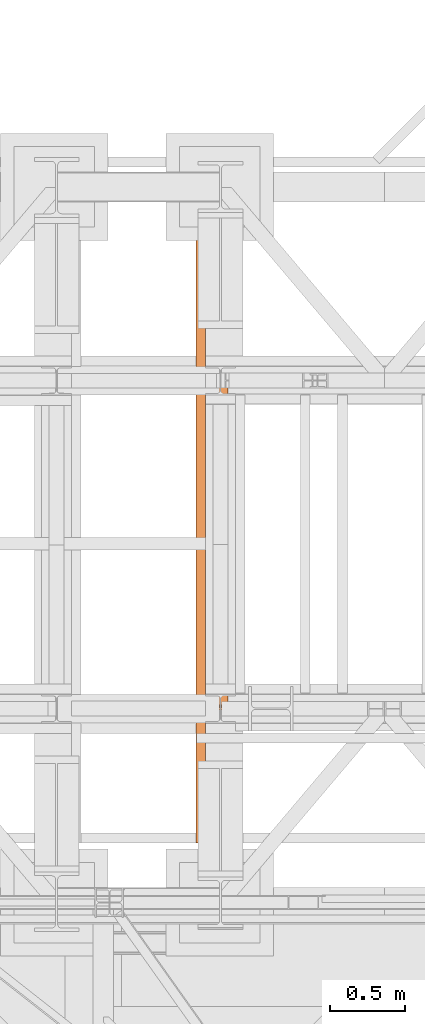
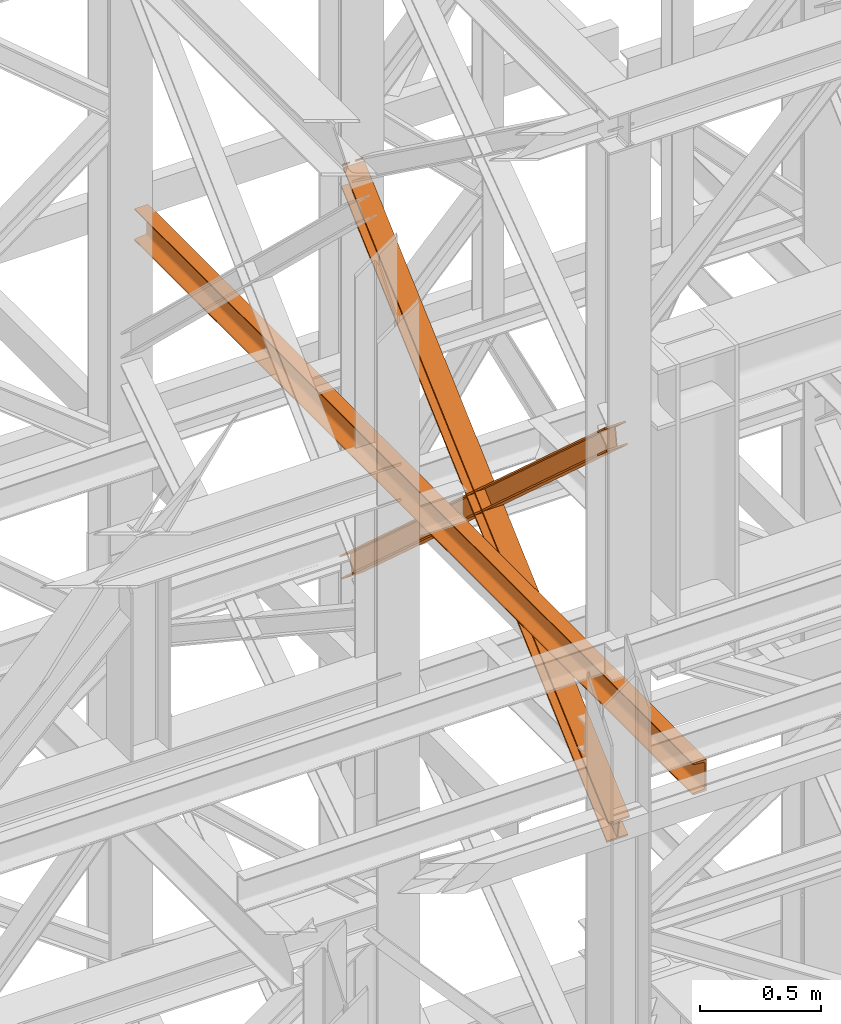
# One storey, part 126 of 208: 3 proxies.
"""IFC2X3 building model written with IfcOpenShell, lengths in millimetres."""

from ifc_helpers import new_model, entity, si_unit, converted_unit, frame, origin, origin_with_axes, place, context, subcontext, project, spatial, faceted_brep, element, save


model = new_model("IFC2X3")

# Units and contexts
model_context = context("Model", 3, precision=1e-05, world=origin())
plan_context = context("Plan", 3, precision=1e-05, world=origin())
body_context = subcontext(model_context, "Body", "Model", "MODEL_VIEW")
ifc_project = project(units=[si_unit("LENGTHUNIT", "METRE", prefix="MILLI"), converted_unit("PLANEANGLEUNIT", "DEGREE", entity("IfcPlaneAngleMeasure", 0.0174532925199433), si_unit("PLANEANGLEUNIT", "RADIAN"), dimensions=[0, 0, 0, 0, 0, 0, 0]), si_unit("AREAUNIT", "SQUARE_METRE"), si_unit("VOLUMEUNIT", "CUBIC_METRE")], contexts=[model_context, plan_context])

# Building, storey
building_placement = place(None, origin())
building = spatial("IfcBuilding", under=ifc_project, at=building_placement, CompositionType="COMPLEX")
storey_placement = place(building_placement, origin_with_axes())
storey = spatial("IfcBuildingStorey", under=building, at=storey_placement, Name="Geschoss", CompositionType="ELEMENT")

# Proxies
proxy_1_placement = place(storey_placement, frame((3242.676947659522, -15970.94025142175, 8709.664099392032), z_axis=(0.0, 0.0, 1.0), x_axis=(1.0, 0.0, 0.0)))
element("IfcBuildingElementProxy", 1, at=proxy_1_placement, inside=storey, context=body_context, shape_type="Brep", body=[
    faceted_brep([(100.0233874223195, 2202.524047252906, 1969.026231437971), (100.2041359483605, 16.74193427489081, 0.02100513656296243), (100.2031119106664, 15.34760641933463, 9.331797992270367), (100.0223627570795, 2201.129719715085, 1978.337022171885), (0.02338802788472094, 2202.524047252906, 1969.015226301408), (0.204136553925764, 16.74193427489081, 0.01000000000021828), (100.2041359483605, 16.74193427489081, 0.02100513656296243), (100.0233874223195, 2202.524047252906, 1969.026231437971), (0.02236336264650163, 2201.129719715083, 1978.32601703533), (0.203112516231613, 15.34760641933463, 9.320792855700347), (0.204136553925764, 16.74193427489081, 0.01000000000021828), (0.02338802788472094, 2202.524047252906, 1969.015226301408), (47.52236307500243, 2201.129719715083, 1978.331244475192), (47.70311222858754, 15.34760641933463, 9.326020295562557), (0.203112516231613, 15.34760641933463, 9.320792855700347), (0.02236336264650163, 2201.129719715083, 1978.32601703533), (47.51211642258568, 2187.186444336861, 2071.439151814395), (47.6928718651684, 1.404327856926102, 102.4339488982641), (47.70311222858754, 15.34760641933463, 9.326020295562557), (47.52236307500243, 2201.129719715083, 1978.331244475192), (0.0110594602265337, 2197.850904391578, 2081.040801967907), (0.01123343514518638, 2196.096022801514, 2079.459950003524), (29.30670605184969, 2196.096022801514, 2079.463174010305), (38.62248918838486, 2197.75725418804, 2080.960688188874), (38.72759933923771, 2197.85090439158, 2081.04506277602), (47.51211642258568, 2187.186444336861, 2071.439151814395), (0.0121167102297477, 2187.186444336861, 2071.433924374533), (0.1928721528142887, 1.404327856924283, 102.4287214583947), (47.6928718651684, 1.404327856926102, 102.4339488982641), (0.01000000000021828, 2196.807553171771, 2090.667763094707), (0.01020876990332909, 2194.701695263691, 2088.770740737438), (0.01123343514518638, 2196.096022801514, 2079.459950003524), (0.0110594602265337, 2197.850904391578, 2081.040801967907), (0.0121167102297477, 2187.186444336861, 2071.433924374533), (0.01109204498970939, 2185.792116799039, 2080.744715108447), (0.1918481178249749, 0.00999999999839929, 111.7395143232407), (0.1928721528142887, 1.404327856924283, 102.4287214583947), (100.0099993944386, 2196.80755317177, 2090.67876823127), (100.0102081643418, 2194.701695263691, 2088.781745874001), (71.80672165016404, 2194.701695263691, 2088.778642041782), (62.49088072881023, 2196.362926650216, 2090.274105784663), (61.99182992716487, 2196.80755317177, 2090.674584279774), (0.01109204498970939, 2185.792116799039, 2080.744715108447), (100.0110914394281, 2185.792116799039, 2080.755720245017), (100.1918475122634, 0.00999999999839929, 111.7505194598034), (0.1918481178249749, 0.00999999999839929, 111.7395143232407), (0.01020876990332909, 2194.701695263691, 2088.770740737438), (0.01000000000021828, 2196.807553171771, 2090.667763094707), (39.12153594998199, 2196.807553171771, 2090.672067372672), (38.62250061437408, 2196.362926650216, 2090.271479036817), (29.3067174778389, 2194.701695263691, 2088.773964858256), (100.0110588546631, 2197.85090439158, 2081.051807104463), (100.01123282958, 2196.096022801514, 2079.470955140079), (100.0102081643418, 2194.701695263691, 2088.781745874001), (100.0099993944386, 2196.80755317177, 2090.67876823127), (100.0110914394281, 2185.792116799039, 2080.755720245017), (100.0121161046682, 2187.186444336861, 2071.444929511088), (100.1928715472454, 1.404327856926102, 102.4397265949574), (100.1918475122634, 0.00999999999839929, 111.7505194598034), (52.5121163923086, 2187.186444336861, 2071.439702071226), (52.69287183489314, 1.404327856924283, 102.4344991550879), (100.1928715472454, 1.404327856926102, 102.4397265949574), (100.0121161046682, 2187.186444336861, 2071.444929511088), (71.80671022417482, 2196.096022801516, 2079.467851193831), (100.01123282958, 2196.096022801514, 2079.470955140079), (100.0110588546631, 2197.85090439158, 2081.051807104463), (62.38575589440734, 2197.85090439158, 2081.047666388475), (62.49086930282101, 2197.75725418804, 2080.963314936713), (52.52236304472172, 2201.129719715083, 1978.331794732023), (52.70311219830865, 15.34760641933463, 9.326570552393605), (52.69287183489314, 1.404327856924283, 102.4344991550879), (52.5121163923086, 2187.186444336861, 2071.439702071226), (100.0223627570795, 2201.129719715085, 1978.337022171885), (100.2031119106664, 15.34760641933463, 9.331797992270367), (52.70311219830865, 15.34760641933463, 9.326570552393605), (52.52236304472172, 2201.129719715083, 1978.331794732023), (62.38575589440734, 2197.85090439158, 2081.047666388475), (100.0110588546631, 2197.85090439158, 2081.051807104463), (100.0099993944386, 2196.80755317177, 2090.67876823127), (61.99182992716487, 2196.80755317177, 2090.674584279774), (39.12153594998199, 2196.807553171771, 2090.672067372672), (0.01000000000021828, 2196.807553171771, 2090.667763094707), (0.0110594602265337, 2197.850904391578, 2081.040801967907), (38.72759933923771, 2197.85090439158, 2081.04506277602), (62.49086930282101, 2197.75725418804, 2080.963314936713), (62.38575589440734, 2197.85090439158, 2081.047666388475), (61.99182992716487, 2196.80755317177, 2090.674584279774), (62.49088072881023, 2196.362926650216, 2090.274105784663), (62.49088072881023, 2196.362926650216, 2090.274105784663), (71.80672165016404, 2194.701695263691, 2088.778642041782), (71.80671022417482, 2196.096022801516, 2079.467851193831), (62.49086930282101, 2197.75725418804, 2080.963314936713), (71.80672165016404, 2194.701695263691, 2088.778642041782), (100.0102081643418, 2194.701695263691, 2088.781745874001), (100.01123282958, 2196.096022801514, 2079.470955140079), (71.80671022417482, 2196.096022801516, 2079.467851193831), (100.0223627570795, 2201.129719715085, 1978.337022171885), (52.52236304472172, 2201.129719715083, 1978.331794732023), (52.5121163923086, 2187.186444336861, 2071.439702071226), (100.0121161046682, 2187.186444336861, 2071.444929511088), (100.0110914394281, 2185.792116799039, 2080.755720245017), (0.01109204498970939, 2185.792116799039, 2080.744715108447), (0.0121167102297477, 2187.186444336861, 2071.433924374533), (47.51211642258568, 2187.186444336861, 2071.439151814395), (47.52236307500243, 2201.129719715083, 1978.331244475192), (0.02236336264650163, 2201.129719715083, 1978.32601703533), (0.02338802788472094, 2202.524047252906, 1969.015226301408), (100.0233874223195, 2202.524047252906, 1969.026231437971), (29.30670605184969, 2196.096022801514, 2079.463174010305), (0.01123343514518638, 2196.096022801514, 2079.459950003524), (0.01020876990332909, 2194.701695263691, 2088.770740737438), (29.3067174778389, 2194.701695263691, 2088.773964858256), (29.3067174778389, 2194.701695263691, 2088.773964858256), (38.62250061437408, 2196.362926650216, 2090.271479036817), (38.62248918838486, 2197.75725418804, 2080.960688188874), (29.30670605184969, 2196.096022801514, 2079.463174010305), (38.62250061437408, 2196.362926650216, 2090.271479036817), (39.12153594998199, 2196.807553171771, 2090.672067372672), (38.72759933923771, 2197.85090439158, 2081.04506277602), (38.62248918838486, 2197.75725418804, 2080.960688188874), (100.2041359483605, 16.74193427489081, 0.02100513656296243), (0.204136553925764, 16.74193427489081, 0.01000000000021828), (0.203112516231613, 15.34760641933463, 9.320792855700347), (47.70311222858754, 15.34760641933463, 9.326020295562557), (47.6928718651684, 1.404327856926102, 102.4339488982641), (0.1928721528142887, 1.404327856924283, 102.4287214583947), (0.1918481178249749, 0.00999999999839929, 111.7395143232407), (100.1918475122634, 0.00999999999839929, 111.7505194598034), (100.1928715472454, 1.404327856926102, 102.4397265949574), (52.69287183489314, 1.404327856924283, 102.4344991550879), (52.70311219830865, 15.34760641933463, 9.326570552393605), (100.2031119106664, 15.34760641933463, 9.331797992270367)], [[[0, 1, 2, 3]], [[4, 5, 6, 7]], [[8, 9, 10, 11]], [[12, 13, 14, 15]], [[16, 17, 18, 19]], [[20, 21, 22, 23, 24]], [[25, 26, 27, 28]], [[29, 30, 31, 32]], [[33, 34, 35, 36]], [[37, 38, 39, 40, 41]], [[42, 43, 44, 45]], [[46, 47, 48, 49, 50]], [[51, 52, 53, 54]], [[55, 56, 57, 58]], [[59, 60, 61, 62]], [[63, 64, 65, 66, 67]], [[68, 69, 70, 71]], [[72, 73, 74, 75]], [[76, 77, 78, 79]], [[80, 81, 82, 83]], [[84, 85, 86, 87]], [[88, 89, 90, 91]], [[92, 93, 94, 95]], [[96, 97, 98, 99, 100, 101, 102, 103, 104, 105, 106, 107]], [[108, 109, 110, 111]], [[112, 113, 114, 115]], [[116, 117, 118, 119]], [[120, 121, 122, 123, 124, 125, 126, 127, 128, 129, 130, 131]]], orient=[[False], [False], [False], [False], [False], [False], [False], [False], [False], [False], [False], [False], [False], [False], [False], [False], [False], [False], [False], [False], [False], [False], [False], [False], [False], [False], [False], [False]]),
])
proxy_2_placement = place(storey_placement, frame((3242.73408746112, -15954.28145682049, 8709.631705441292), z_axis=(0.0, 0.0, 1.0), x_axis=(1.0, 0.0, 0.0)))
element("IfcBuildingElementProxy", 2, at=proxy_2_placement, inside=storey, context=body_context, shape_type="Brep", body=[
    faceted_brep([(100.0202537490113, 1.404418357440591, 1976.169685278082), (100.1537894349171, 2184.74959498962, 9.331916248220296), (100.1547211341535, 2183.35672227913, 0.0197810693334759), (100.0211859525844, 0.01154596052219858, 1966.857552195595), (100.0211859525844, 0.01154596052219858, 1966.857552195595), (100.1547211341535, 2183.35672227913, 0.0197810693334759), (0.1547216244512129, 2183.355176318608, 0.01000000000021828), (0.02118644288202631, 0.01000000000021828, 1966.847771126266), (0.02118644288202631, 0.01000000000021828, 1966.847771126266), (0.1547216244512129, 2183.355176318608, 0.01000000000021828), (0.1537899252166426, 2184.748049029098, 9.322135178887038), (0.02025423930899706, 1.40287239691861, 1976.159904208749), (0.02025423930899706, 1.40287239691861, 1976.159904208749), (0.1537899252166426, 2184.748049029098, 9.322135178887038), (47.65378969232779, 2184.748783360346, 9.326781186826338), (47.52025400642015, 1.403606728164959, 1976.164550216681), (47.52025400642015, 1.403606728164959, 1976.164550216681), (47.65378969232779, 2184.748783360346, 9.326781186826338), (47.64447271073777, 2198.677510471935, 102.4481330204089), (47.51093197068258, 15.33233069734524, 2069.285881041526), (47.51093197068258, 15.33233069734524, 2069.285881041526), (47.64447271073777, 2198.677510471935, 102.4481330204089), (0.1444729436284433, 2198.676776140686, 102.4434870124769), (0.01093220357506652, 15.33159636609526, 2069.281235033586), (0.01093220357506652, 15.33159636609526, 2069.281235033586), (0.1444729436284433, 2198.676776140686, 102.4434870124769), (0.1435412465457375, 2200.069648852516, 111.7556222003168), (0.01000000000021828, 16.72446876301547, 2078.593368116077), (0.01000000000021828, 16.72446876301547, 2078.593368116077), (0.1435412465457375, 2200.069648852516, 111.7556222003168), (100.1435407562481, 2200.071194813039, 111.7654032696537), (100.0099995097044, 16.72601472353745, 2078.603149185414), (100.0099995097044, 16.72601472353745, 2078.603149185414), (100.1435407562481, 2200.071194813039, 111.7654032696537), (100.1444724533308, 2198.67832210121, 102.4532680818102), (100.0109317132756, 15.33314232661905, 2069.29101610293), (100.0109317132756, 15.33314232661905, 2069.29101610293), (100.1444724533308, 2198.67832210121, 102.4532680818102), (52.64447268622143, 2198.677587769962, 102.4486220738781), (52.51093194616988, 15.33240799537089, 2069.286370094991), (52.51093194616988, 15.33240799537089, 2069.286370094991), (52.64447268622143, 2198.677587769962, 102.4486220738781), (52.65378966781145, 2184.748860658372, 9.327270240288271), (52.52025398190563, 1.403684026192423, 1976.165039270154), (52.52025398190563, 1.403684026192423, 1976.165039270154), (52.65378966781145, 2184.748860658372, 9.327270240288271), (100.1537894349171, 2184.74959498962, 9.331916248220296), (100.0202537490113, 1.404418357440591, 1976.169685278082), (100.0211859525844, 0.01154596052219858, 1966.857552195595), (0.02118644288202631, 0.01000000000021828, 1966.847771126266), (0.02025423930899706, 1.40287239691861, 1976.159904208749), (47.52025400642015, 1.403606728164959, 1976.164550216681), (47.51093197068258, 15.33233069734524, 2069.285881041526), (0.01093220357506652, 15.33159636609526, 2069.281235033586), (0.01000000000021828, 16.72446876301547, 2078.593368116077), (100.0099995097044, 16.72601472353745, 2078.603149185414), (100.0109317132756, 15.33314232661905, 2069.29101610293), (52.51093194616988, 15.33240799537089, 2069.286370094991), (52.52025398190563, 1.403684026192423, 1976.165039270154), (100.0202537490113, 1.404418357440591, 1976.169685278082), (100.1537894349171, 2184.74959498962, 9.331916248220296), (52.65378966781145, 2184.748860658372, 9.327270240288271), (52.64447268622143, 2198.677587769962, 102.4486220738781), (100.1444724533308, 2198.67832210121, 102.4532680818102), (100.1435407562481, 2200.071194813039, 111.7654032696537), (0.1435412465457375, 2200.069648852516, 111.7556222003168), (0.1444729436284433, 2198.676776140686, 102.4434870124769), (47.64447271073777, 2198.677510471935, 102.4481330204089), (47.65378969232779, 2184.748783360346, 9.326781186826338), (0.1537899252166426, 2184.748049029098, 9.322135178887038), (0.1547216244512129, 2183.355176318608, 0.01000000000021828), (100.1547211341535, 2183.35672227913, 0.0197810693334759)], [[[0, 1, 2, 3]], [[4, 5, 6, 7]], [[8, 9, 10, 11]], [[12, 13, 14, 15]], [[16, 17, 18, 19]], [[20, 21, 22, 23]], [[24, 25, 26, 27]], [[28, 29, 30, 31]], [[32, 33, 34, 35]], [[36, 37, 38, 39]], [[40, 41, 42, 43]], [[44, 45, 46, 47]], [[48, 49, 50, 51, 52, 53, 54, 55, 56, 57, 58, 59]], [[60, 61, 62, 63, 64, 65, 66, 67, 68, 69, 70, 71]]], orient=[[False], [False], [False], [False], [False], [False], [False], [False], [False], [False], [False], [False], [False], [False]]),
])
proxy_3_placement = place(storey_placement, frame((3128.254967038547, -16862.41513545784, 9539.99), z_axis=(0.0, 0.0, 1.0), x_axis=(1.0, 0.0, 0.0)))
element("IfcBuildingElementProxy", 3, at=proxy_3_placement, inside=storey, context=body_context, shape_type="Brep", body=[
    faceted_brep([(0.0654330339993976, 4599.719633650035, 0.01000000000021828), (0.0654330339993976, 4599.719633650035, 3.132428070246533), (0.01000000000021828, 0.00999999999839929, 3.132428070246533), (0.01000000000021828, 0.00999999999839929, 0.01000000000021828), (0.0654330339993976, 4599.719633650035, 3.132428070246533), (0.3081696111730707, 4599.719633650035, 4.748288908171162), (0.2527365771738914, 0.00999999999839929, 4.748288908171162), (0.01000000000021828, 0.00999999999839929, 3.132428070246533), (0.3081696111730707, 4599.719633650035, 4.748288908171162), (1.0149007481441, 4599.719633650035, 6.221534443444398), (0.9594677141440116, 0.00999999999839929, 6.221534443444398), (0.2527365771738914, 0.00999999999839929, 4.748288908171162), (1.0149007481441, 4599.719633650035, 6.221534443444398), (2.123281395531194, 4599.719633650035, 7.422126703873801), (2.067848361531105, 0.00999999999839929, 7.422126703873801), (0.9594677141440116, 0.00999999999839929, 6.221534443444398), (2.123281395531194, 4599.719633650035, 7.422126703873801), (3.53547662251458, 4599.719633650035, 8.244091391710754), (3.4800435885154, 0.00999999999839929, 8.244091391710754), (2.067848361531105, 0.00999999999839929, 7.422126703873801), (3.53547662251458, 4599.719633650035, 8.244091391710754), (5.126834311443417, 4599.719633650035, 8.614912102195376), (5.071401277444238, 0.00999999999839929, 8.614912102195376), (3.4800435885154, 0.00999999999839929, 8.244091391710754), (5.126834311443417, 4599.719633650035, 8.614912102195376), (47.90275786796974, 4599.719633650035, 12.0369859867169), (47.84732483397056, 0.00999999999839929, 12.0369859867169), (5.071401277444238, 0.00999999999839929, 8.614912102195376), (47.90275786796974, 4599.719633650035, 12.0369859867169), (50.94080436501554, 4599.719633650035, 12.74491643400506), (50.88537133101636, 0.00999999999839929, 12.74491643400506), (47.84732483397056, 0.00999999999839929, 12.0369859867169), (50.94080436501554, 4599.719633650035, 12.74491643400506), (53.63681343471308, 4599.719633650035, 14.31412174714933), (53.5813804007139, 0.00999999999839929, 14.31412174714933), (50.88537133101636, 0.00999999999839929, 12.74491643400506), (53.63681343471308, 4599.719633650035, 14.31412174714933), (55.75281285245274, 4599.719633650035, 16.60616151705835), (55.69737981845356, 0.00999999999839929, 16.60616151705835), (53.5813804007139, 0.00999999999839929, 14.31412174714933), (55.75281285245274, 4599.719633650035, 16.60616151705835), (57.10202684121396, 4599.719633650035, 19.41872117530875), (57.04659380721387, 0.00999999999839929, 19.41872117530875), (55.69737981845356, 0.00999999999839929, 16.60616151705835), (57.10202684121396, 4599.719633650035, 19.41872117530875), (57.5654330339994, 4599.719633650035, 22.50354641134618), (57.51000000000022, 0.00999999999839929, 22.50354641134618), (57.04659380721387, 0.00999999999839929, 19.41872117530875), (57.5654330339994, 4599.719633650035, 22.50354641134618), (57.5654330339994, 4599.719633650035, 137.5164535886524), (57.51000000000022, 0.00999999999839929, 137.5164535886524), (57.51000000000022, 0.00999999999839929, 22.50354641134618), (57.5654330339994, 4599.719633650035, 137.5164535886524), (57.10202684121396, 4599.719633650035, 140.6012788246917), (57.04659380721387, 0.00999999999839929, 140.6012788246917), (57.51000000000022, 0.00999999999839929, 137.5164535886524), (57.10202684121396, 4599.719633650035, 140.6012788246917), (55.75281285245274, 4599.719633650035, 143.4138384829403), (55.69737981845356, 0.00999999999839929, 143.4138384829403), (57.04659380721387, 0.00999999999839929, 140.6012788246917), (55.75281285245274, 4599.719633650035, 143.4138384829403), (53.63681343471308, 4599.719633650035, 145.7058782528493), (53.5813804007139, 0.00999999999839929, 145.7058782528493), (55.69737981845356, 0.00999999999839929, 143.4138384829403), (53.63681343471308, 4599.719633650035, 145.7058782528493), (50.94080436501554, 4599.719633650035, 147.2750835659936), (50.88537133101636, 0.00999999999839929, 147.2750835659936), (53.5813804007139, 0.00999999999839929, 145.7058782528493), (50.94080436501554, 4599.719633650035, 147.2750835659936), (47.90275786796974, 4599.719633650035, 147.9830140132817), (47.84732483397056, 0.00999999999839929, 147.9830140132817), (50.88537133101636, 0.00999999999839929, 147.2750835659936), (47.90275786796974, 4599.719633650035, 147.9830140132817), (5.126834311443417, 4599.719633650035, 151.4050878978032), (5.071401277444238, 0.00999999999839929, 151.4050878978032), (47.84732483397056, 0.00999999999839929, 147.9830140132817), (5.126834311443417, 4599.719633650035, 151.4050878978032), (3.53547662251458, 4599.719633650035, 151.7759086082879), (3.4800435885154, 0.00999999999839929, 151.7759086082879), (5.071401277444238, 0.00999999999839929, 151.4050878978032), (3.53547662251458, 4599.719633650035, 151.7759086082879), (2.123281395531194, 4599.719633650035, 152.5978732961248), (2.067848361531105, 0.00999999999839929, 152.5978732961248), (3.4800435885154, 0.00999999999839929, 151.7759086082879), (2.123281395531194, 4599.719633650035, 152.5978732961248), (1.0149007481441, 4599.719633650035, 153.7984655565542), (0.9594677141440116, 0.00999999999839929, 153.7984655565542), (2.067848361531105, 0.00999999999839929, 152.5978732961248), (1.0149007481441, 4599.719633650035, 153.7984655565542), (0.3081696111730707, 4599.719633650035, 155.2717110918275), (0.2527365771738914, 0.00999999999839929, 155.2717110918275), (0.9594677141440116, 0.00999999999839929, 153.7984655565542), (0.3081696111730707, 4599.719633650035, 155.2717110918275), (0.0654330339993976, 4599.719633650035, 156.8875719297521), (0.01000000000021828, 0.00999999999839929, 156.8875719297521), (0.2527365771738914, 0.00999999999839929, 155.2717110918275), (0.0654330339993976, 4599.719633650035, 156.8875719297521), (0.0654330339993976, 4599.719633650035, 160.0100000000002), (0.01000000000021828, 0.00999999999839929, 160.0100000000002), (0.01000000000021828, 0.00999999999839929, 156.8875719297521), (0.0654330339993976, 4599.719633650035, 160.0100000000002), (65.0654330339994, 4599.719633650035, 160.0100000000002), (65.01000000000022, 0.00999999999839929, 160.0100000000002), (0.01000000000021828, 0.00999999999839929, 160.0100000000002), (65.0654330339994, 4599.719633650035, 160.0100000000002), (65.0654330339994, 4599.719633650035, 0.01000000000021828), (65.01000000000022, 0.00999999999839929, 0.01000000000021828), (65.01000000000022, 0.00999999999839929, 160.0100000000002), (65.0654330339994, 4599.719633650035, 0.01000000000021828), (0.0654330339993976, 4599.719633650035, 0.01000000000021828), (0.01000000000021828, 0.00999999999839929, 0.01000000000021828), (65.01000000000022, 0.00999999999839929, 0.01000000000021828), (0.0654330339993976, 4599.719633650035, 0.01000000000021828), (65.0654330339994, 4599.719633650035, 0.01000000000021828), (65.0654330339994, 4599.719633650035, 160.0100000000002), (0.0654330339993976, 4599.719633650035, 160.0100000000002), (0.0654330339993976, 4599.719633650035, 156.8875719297521), (0.3081696111730707, 4599.719633650035, 155.2717110918275), (1.0149007481441, 4599.719633650035, 153.7984655565542), (2.123281395531194, 4599.719633650035, 152.5978732961248), (3.53547662251458, 4599.719633650035, 151.7759086082879), (5.126834311443417, 4599.719633650035, 151.4050878978032), (47.90275786796974, 4599.719633650035, 147.9830140132817), (50.94080436501554, 4599.719633650035, 147.2750835659936), (53.63681343471308, 4599.719633650035, 145.7058782528493), (55.75281285245274, 4599.719633650035, 143.4138384829403), (57.10202684121396, 4599.719633650035, 140.6012788246917), (57.5654330339994, 4599.719633650035, 137.5164535886524), (57.5654330339994, 4599.719633650035, 22.50354641134618), (57.10202684121396, 4599.719633650035, 19.41872117530875), (55.75281285245274, 4599.719633650035, 16.60616151705835), (53.63681343471308, 4599.719633650035, 14.31412174714933), (50.94080436501554, 4599.719633650035, 12.74491643400506), (47.90275786796974, 4599.719633650035, 12.0369859867169), (5.126834311443417, 4599.719633650035, 8.614912102195376), (3.53547662251458, 4599.719633650035, 8.244091391710754), (2.123281395531194, 4599.719633650035, 7.422126703873801), (1.0149007481441, 4599.719633650035, 6.221534443444398), (0.3081696111730707, 4599.719633650035, 4.748288908171162), (0.0654330339993976, 4599.719633650035, 3.132428070246533), (0.01000000000021828, 0.00999999999839929, 0.01000000000021828), (0.01000000000021828, 0.00999999999839929, 3.132428070246533), (0.2527365771738914, 0.00999999999839929, 4.748288908171162), (0.9594677141440116, 0.00999999999839929, 6.221534443444398), (2.067848361531105, 0.00999999999839929, 7.422126703873801), (3.4800435885154, 0.00999999999839929, 8.244091391710754), (5.071401277444238, 0.00999999999839929, 8.614912102195376), (47.84732483397056, 0.00999999999839929, 12.0369859867169), (50.88537133101636, 0.00999999999839929, 12.74491643400506), (53.5813804007139, 0.00999999999839929, 14.31412174714933), (55.69737981845356, 0.00999999999839929, 16.60616151705835), (57.04659380721387, 0.00999999999839929, 19.41872117530875), (57.51000000000022, 0.00999999999839929, 22.50354641134618), (57.51000000000022, 0.00999999999839929, 137.5164535886524), (57.04659380721387, 0.00999999999839929, 140.6012788246917), (55.69737981845356, 0.00999999999839929, 143.4138384829403), (53.5813804007139, 0.00999999999839929, 145.7058782528493), (50.88537133101636, 0.00999999999839929, 147.2750835659936), (47.84732483397056, 0.00999999999839929, 147.9830140132817), (5.071401277444238, 0.00999999999839929, 151.4050878978032), (3.4800435885154, 0.00999999999839929, 151.7759086082879), (2.067848361531105, 0.00999999999839929, 152.5978732961248), (0.9594677141440116, 0.00999999999839929, 153.7984655565542), (0.2527365771738914, 0.00999999999839929, 155.2717110918275), (0.01000000000021828, 0.00999999999839929, 156.8875719297521), (0.01000000000021828, 0.00999999999839929, 160.0100000000002), (65.01000000000022, 0.00999999999839929, 160.0100000000002), (65.01000000000022, 0.00999999999839929, 0.01000000000021828)], [[[0, 1, 2, 3]], [[4, 5, 6, 7]], [[8, 9, 10, 11]], [[12, 13, 14, 15]], [[16, 17, 18, 19]], [[20, 21, 22, 23]], [[24, 25, 26, 27]], [[28, 29, 30, 31]], [[32, 33, 34, 35]], [[36, 37, 38, 39]], [[40, 41, 42, 43]], [[44, 45, 46, 47]], [[48, 49, 50, 51]], [[52, 53, 54, 55]], [[56, 57, 58, 59]], [[60, 61, 62, 63]], [[64, 65, 66, 67]], [[68, 69, 70, 71]], [[72, 73, 74, 75]], [[76, 77, 78, 79]], [[80, 81, 82, 83]], [[84, 85, 86, 87]], [[88, 89, 90, 91]], [[92, 93, 94, 95]], [[96, 97, 98, 99]], [[100, 101, 102, 103]], [[104, 105, 106, 107]], [[108, 109, 110, 111]], [[112, 113, 114, 115, 116, 117, 118, 119, 120, 121, 122, 123, 124, 125, 126, 127, 128, 129, 130, 131, 132, 133, 134, 135, 136, 137, 138, 139]], [[140, 141, 142, 143, 144, 145, 146, 147, 148, 149, 150, 151, 152, 153, 154, 155, 156, 157, 158, 159, 160, 161, 162, 163, 164, 165, 166, 167]]], orient=[[False], [False], [False], [False], [False], [False], [False], [False], [False], [False], [False], [False], [False], [False], [False], [False], [False], [False], [False], [False], [False], [False], [False], [False], [False], [False], [False], [False], [False], [False]]),
])

save(model, "model.ifc")
